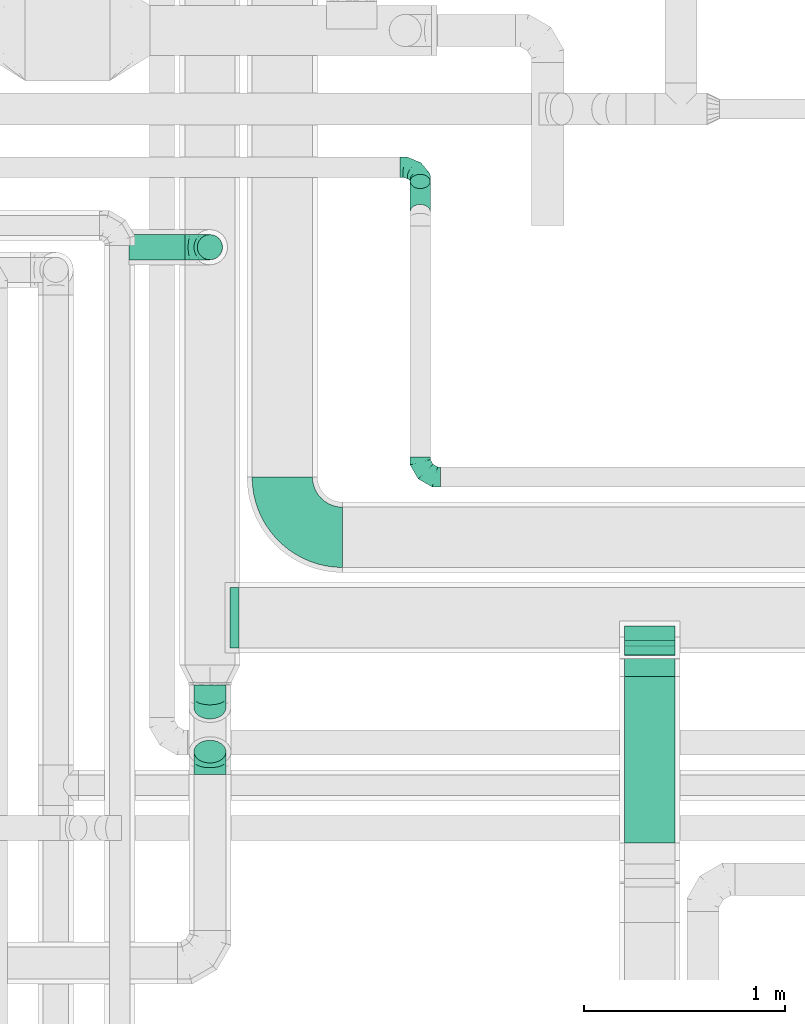
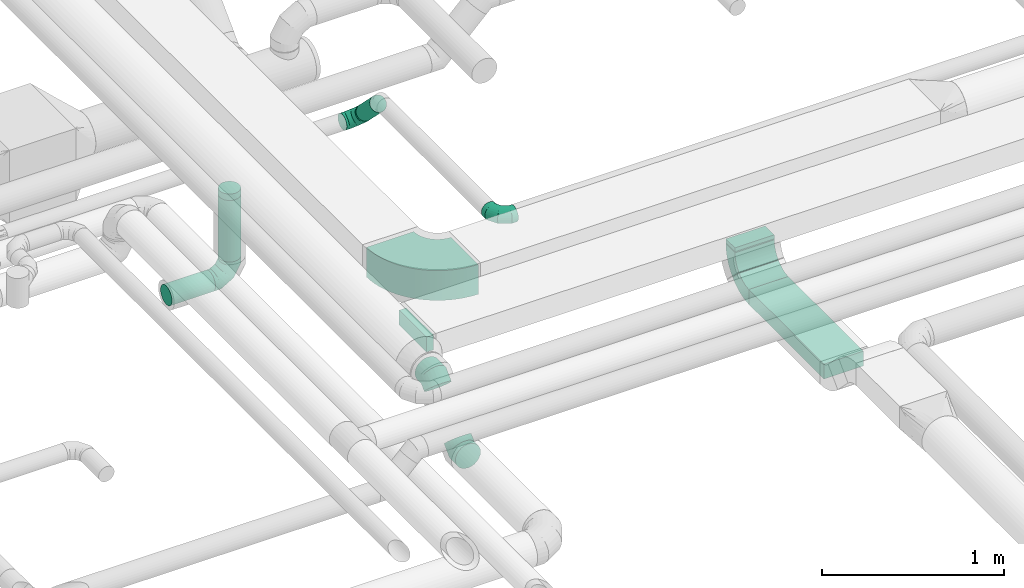
# One storey, part 68 of 92: 11 flow fittings, 6 flow segments.
"""IFC2X3 building model written with IfcOpenShell, lengths in millimetres."""

from ifc_helpers import new_model, entity, si_unit, converted_unit, derived_unit, direction, frame, frame_2d, origin, origin_2d_with_axis, place, context, subcontext, project, spatial, polyline, circle_curve, parameter, trimmed, segment, composite_curve, rectangle, circle, outline, extrude, faceted_brep, source, transform, mapped, material, type_object, type_shapes, element, save


model = new_model("IFC2X3")

# Units and contexts
model_context = context("Model", 3, precision=0.01, world=origin(), true_north=direction((6.12303176911189e-17, 1.0)))
body_context = subcontext(model_context, "Body", "Model", "MODEL_VIEW")
ifc_project = project(units=[si_unit("LENGTHUNIT", "METRE", prefix="MILLI"), si_unit("AREAUNIT", "SQUARE_METRE"), si_unit("VOLUMEUNIT", "CUBIC_METRE"), converted_unit("PLANEANGLEUNIT", "DEGREE", entity("IfcRatioMeasure", 0.0174532925199433), si_unit("PLANEANGLEUNIT", "RADIAN"), dimensions=[0, 0, 0, 0, 0, 0, 0]), si_unit("MASSUNIT", "GRAM", prefix="KILO"), derived_unit("MASSDENSITYUNIT", [(si_unit("MASSUNIT", "GRAM", prefix="KILO"), 1), (si_unit("LENGTHUNIT", "METRE"), -3)]), derived_unit("MOMENTOFINERTIAUNIT", [(si_unit("LENGTHUNIT", "METRE"), 4)]), si_unit("TIMEUNIT", "SECOND"), si_unit("FREQUENCYUNIT", "HERTZ"), si_unit("THERMODYNAMICTEMPERATUREUNIT", "DEGREE_CELSIUS"), derived_unit("THERMALTRANSMITTANCEUNIT", [(si_unit("MASSUNIT", "GRAM", prefix="KILO"), 1), (si_unit("THERMODYNAMICTEMPERATUREUNIT", "KELVIN"), -1), (si_unit("TIMEUNIT", "SECOND"), -3)]), derived_unit("VOLUMETRICFLOWRATEUNIT", [(si_unit("LENGTHUNIT", "METRE"), 3), (si_unit("TIMEUNIT", "SECOND"), -1)]), derived_unit("MASSFLOWRATEUNIT", [(si_unit("MASSUNIT", "GRAM", prefix="KILO"), 1), (si_unit("TIMEUNIT", "SECOND"), -1)]), derived_unit("ROTATIONALFREQUENCYUNIT", [(si_unit("TIMEUNIT", "SECOND"), -1)]), si_unit("ELECTRICCURRENTUNIT", "AMPERE"), si_unit("ELECTRICVOLTAGEUNIT", "VOLT"), si_unit("POWERUNIT", "WATT"), si_unit("FORCEUNIT", "NEWTON", prefix="KILO"), si_unit("ILLUMINANCEUNIT", "LUX"), si_unit("LUMINOUSFLUXUNIT", "LUMEN"), si_unit("LUMINOUSINTENSITYUNIT", "CANDELA"), derived_unit("USERDEFINED", [(si_unit("MASSUNIT", "GRAM", prefix="KILO"), -1), (si_unit("LENGTHUNIT", "METRE"), -2), (si_unit("TIMEUNIT", "SECOND"), 3), (si_unit("LUMINOUSFLUXUNIT", "LUMEN"), 1)]), derived_unit("LINEARVELOCITYUNIT", [(si_unit("LENGTHUNIT", "METRE"), 1), (si_unit("TIMEUNIT", "SECOND"), -1)]), si_unit("PRESSUREUNIT", "PASCAL"), derived_unit("USERDEFINED", [(si_unit("LENGTHUNIT", "METRE"), -2), (si_unit("MASSUNIT", "GRAM", prefix="KILO"), 1), (si_unit("TIMEUNIT", "SECOND"), -2)]), derived_unit("LINEARFORCEUNIT", [(si_unit("MASSUNIT", "GRAM", prefix="KILO"), 1), (si_unit("LENGTHUNIT", "METRE"), 1), (si_unit("TIMEUNIT", "SECOND"), -2), (si_unit("LENGTHUNIT", "METRE"), -1)]), derived_unit("PLANARFORCEUNIT", [(si_unit("MASSUNIT", "GRAM", prefix="KILO"), 1), (si_unit("LENGTHUNIT", "METRE"), 1), (si_unit("TIMEUNIT", "SECOND"), -2), (si_unit("LENGTHUNIT", "METRE"), -2)])], contexts=[model_context])

# Site, building, storey
site_placement = place(None, origin())
site = spatial("IfcSite", under=ifc_project, at=site_placement, CompositionType="ELEMENT")
building_placement = place(site_placement, origin())
building = spatial("IfcBuilding", under=site, at=building_placement, CompositionType="ELEMENT")
storey_placement = place(building_placement, frame((0.0, 0.0, 4200.0)))
storey = spatial("IfcBuildingStorey", under=building, at=storey_placement, CompositionType="ELEMENT", Elevation=4200.0)

# Flow segments
duct_segment_type_1 = type_object("IfcDuctSegmentType", PredefinedType="NOTDEFINED")
flow_segment_1_placement = place(storey_placement, frame((63146.35, 8456.55, 2970.0)))
element("IfcFlowSegment", 1, at=flow_segment_1_placement, inside=storey, type_object=duct_segment_type_1, context=body_context, shape_type="SweptSolid", body=[
    extrude(rectangle(XDim=825.783728094219, YDim=250.000000000004, at=origin_2d_with_axis()), frame((125.0, 412.89, 0.0), z_axis=(0.0, 0.0, 1.0), x_axis=(0.0, 1.0, 0.0)), (0.0, 0.0, 1.0), 99.9999999999989),
])
flow_segment_2_placement = place(storey_placement, frame((63146.35, 9435.17, 3222.84)))
element("IfcFlowSegment", 2, at=flow_segment_2_placement, inside=storey, type_object=duct_segment_type_1, context=body_context, shape_type="SweptSolid", body=[
    extrude(rectangle(XDim=249.999999999995, YDim=100.0, at=origin_2d_with_axis()), frame((125.0, 50.0, 0.0)), (0.0, 0.0, 1.0), 7.15728752542948),
])
flow_segment_3_placement = place(storey_placement, frame((63146.35, 9388.4, 3043.22)))
element("IfcFlowSegment", 3, at=flow_segment_3_placement, inside=storey, type_object=duct_segment_type_1, context=body_context, shape_type="SweptSolid", body=[
    extrude(rectangle(XDim=99.9999999999997, YDim=4.02020253560479, at=frame_2d((0.0, 0.0), x_axis=(0.0, 1.0))), frame((0.0, 36.78, 36.78), z_axis=(1.0, 0.0, 0.0), x_axis=(0.0, 0.707106781190723, 0.707106781182372)), (0.0, 0.0, 1.0), 249.999999999995),
])
duct_segment_type_2 = type_object("IfcDuctSegmentType", PredefinedType="NOTDEFINED")
flow_segment_4_placement = place(storey_placement, frame((60683.72, 11352.66, 2535.9)))
element("IfcFlowSegment", 4, at=flow_segment_4_placement, inside=storey, type_object=duct_segment_type_2, context=body_context, shape_type="SweptSolid", body=[
    extrude(circle(Radius=62.5, at=origin_2d_with_axis()), frame((0.0, 64.1, 64.1), z_axis=(1.0, 0.0, 0.0), x_axis=(0.0, -1.0, 0.0)), (0.0, 0.0, 1.0), 276.27551312413),
])
flow_segment_5_placement = place(storey_placement, frame((61020.9, 11352.66, 2725.0)))
element("IfcFlowSegment", 5, at=flow_segment_5_placement, inside=storey, type_object=duct_segment_type_2, context=body_context, shape_type="SweptSolid", body=[
    extrude(circle(Radius=62.5, at=origin_2d_with_axis()), frame((64.1, 64.1, 0.0), z_axis=(0.0, 0.0, 1.0), x_axis=(0.0, -1.0, 0.0)), (0.0, 0.0, 1.0), 412.500000000016),
])
duct_segment_type_3 = type_object("IfcDuctSegmentType", PredefinedType="NOTDEFINED")
flow_segment_6_placement = place(storey_placement, frame((62078.4, 11556.54, 3083.76)))
element("IfcFlowSegment", 6, at=flow_segment_6_placement, inside=storey, type_object=duct_segment_type_3, context=body_context, shape_type="SweptSolid", body=[
    extrude(circle(Radius=50.0, at=origin_2d_with_axis()), frame((51.6, 186.95, 36.95), z_axis=(0.0, -0.707106781186563, 0.707106781186532), x_axis=(-1.0, 0.0, 0.0)), (0.0, 0.0, 1.0), 212.132034355984),
])

# Flow fittings
ifc_material = material()
duct_fitting_type_1 = type_object("IfcDuctFittingType", PredefinedType="NOTDEFINED", material=ifc_material)
shared_shape_1 = source(origin(), body_context, "Body", "SweptSolid", [
    extrude(rectangle(XDim=300.0, YDim=44.6568108823504, at=origin_2d_with_axis()), frame((-2.33, 0.0, -50.0), z_axis=(0.0, 0.0, 1.0), x_axis=(0.0, -1.0, 0.0)), (0.0, 0.0, 1.0), 100.0),
])
type_shapes(duct_fitting_type_1, [shared_shape_1])
flow_fitting_1_placement = place(storey_placement, frame((61208.77, 9575.17, 3300.0), z_axis=(0.0, 0.0, -1.0), x_axis=(1.0, 0.0, 0.0)))
element("IfcFlowFitting", 7, at=flow_fitting_1_placement, inside=storey, type_object=duct_fitting_type_1, material=ifc_material, context=body_context, shape_type="MappedRepresentation", body=[
    mapped(shared_shape_1, transform((0.0, 0.0, 0.0), scale=1.0)),
])
duct_fitting_type_2 = type_object("IfcDuctFittingType", PredefinedType="NOTDEFINED", material=ifc_material)
shared_shape_2 = source(origin(), body_context, "Body", "SweptSolid", [
    extrude(rectangle(XDim=250.0, YDim=26.096, at=origin_2d_with_axis()), frame((6.95, 0.0, -50.0), z_axis=(0.0, 0.0, 1.0), x_axis=(0.0, -1.0, 0.0)), (0.0, 0.0, 1.0), 100.0),
])
type_shapes(duct_fitting_type_2, [shared_shape_2])
flow_fitting_2_placement = place(storey_placement, frame((63271.35, 9485.17, 3250.0), z_axis=(0.0, 1.0, 0.0), x_axis=(0.0, 0.0, -1.0)))
element("IfcFlowFitting", 8, at=flow_fitting_2_placement, inside=storey, type_object=duct_fitting_type_2, material=ifc_material, context=body_context, shape_type="MappedRepresentation", body=[
    mapped(shared_shape_2, transform((0.0, 0.0, 0.0), scale=1.0)),
])
duct_fitting_type_3 = type_object("IfcDuctFittingType", PredefinedType="NOTDEFINED", material=ifc_material)
shared_shape_3 = source(origin(), body_context, "Body", "Brep", [
    faceted_brep([(-100.0, 0.0, -50.0), (-100.0, -12.94, -48.3), (-100.0, -25.0, -43.3), (-100.0, -35.36, -35.36), (-100.0, -43.3, -25.0), (-100.0, -48.3, -12.94), (-100.0, -50.0, 0.0), (-100.0, -48.3, 12.94), (-100.0, -43.3, 25.0), (-100.0, -35.36, 35.36), (-100.0, -25.0, 43.3), (-100.0, -12.94, 48.3), (-100.0, 0.0, 50.0), (-100.0, 12.94, 48.3), (-100.0, 25.0, 43.3), (-100.0, 35.36, 35.36), (-100.0, 43.3, 25.0), (-100.0, 48.3, 12.94), (-100.0, 50.0, 0.0), (-100.0, 48.3, -12.94), (-100.0, 43.3, -25.0), (-100.0, 35.36, -35.36), (-100.0, 25.0, -43.3), (-100.0, 12.94, -48.3), (-76.67, 12.94, 48.3), (-79.9, 25.0, 43.3), (-73.21, 0.0, 50.0), (-82.68, 35.36, 35.36), (-86.15, 48.3, 12.94), (-86.6, 50.0, 0.0), (-84.81, 43.3, 25.0), (-84.81, 43.3, -25.0), (-82.68, 35.36, -35.36), (-86.15, 48.3, -12.94), (-76.67, 12.94, -48.3), (-73.21, 0.0, -50.0), (-79.9, 25.0, -43.3), (-69.74, -12.94, -48.3), (-66.51, -25.0, -43.3), (-63.73, -35.36, -35.36), (-61.6, -43.3, -25.0), (-60.26, -48.3, -12.94), (-59.81, -50.0, 0.0), (-60.26, -48.3, 12.94), (-61.6, -43.3, 25.0), (-63.73, -35.36, 35.36), (-66.51, -25.0, 43.3), (-69.74, -12.94, 48.3), (-36.27, 36.27, 48.3), (-45.1, 45.1, 43.3), (-26.79, 26.79, 50.0), (-52.68, 52.68, 35.36), (-58.49, 58.49, 25.0), (-62.15, 62.15, 12.94), (-63.4, 63.4, 0.0), (-62.15, 62.15, -12.94), (-58.49, 58.49, -25.0), (-52.68, 52.68, -35.36), (-36.27, 36.27, -48.3), (-26.79, 26.79, -50.0), (-45.1, 45.1, -43.3), (-17.32, 17.32, -48.3), (-8.49, 8.49, -43.3), (-0.91, 0.91, -35.36), (4.9, -4.9, -25.0), (8.56, -8.56, -12.94), (9.81, -9.81, 0.0), (8.56, -8.56, 12.94), (4.9, -4.9, 25.0), (-0.91, 0.91, 35.36), (-8.49, 8.49, 43.3), (-17.32, 17.32, 48.3), (-12.94, 76.67, 48.3), (-25.0, 79.9, 43.3), (0.0, 73.21, 50.0), (-35.36, 82.68, 35.36), (-43.3, 84.81, 25.0), (-48.3, 86.15, 12.94), (-50.0, 86.6, 0.0), (-48.3, 86.15, -12.94), (-43.3, 84.81, -25.0), (-35.36, 82.68, -35.36), (-12.94, 76.67, -48.3), (0.0, 73.21, -50.0), (-25.0, 79.9, -43.3), (12.94, 69.74, -48.3), (25.0, 66.51, -43.3), (35.36, 63.73, -35.36), (43.3, 61.6, -25.0), (48.3, 60.26, -12.94), (50.0, 59.81, 0.0), (48.3, 60.26, 12.94), (43.3, 61.6, 25.0), (35.36, 63.73, 35.36), (25.0, 66.51, 43.3), (12.94, 69.74, 48.3), (-12.94, 100.0, -48.3), (-25.0, 100.0, -43.3), (-35.36, 100.0, -35.36), (-43.3, 100.0, -25.0), (-48.3, 100.0, -12.94), (-50.0, 100.0, 0.0), (-48.3, 100.0, 12.94), (-43.3, 100.0, 25.0), (-35.36, 100.0, 35.36), (-25.0, 100.0, 43.3), (-12.94, 100.0, 48.3), (0.0, 100.0, 50.0), (12.94, 100.0, 48.3), (25.0, 100.0, 43.3), (35.36, 100.0, 35.36), (43.3, 100.0, 25.0), (48.3, 100.0, 12.94), (50.0, 100.0, 0.0), (48.3, 100.0, -12.94), (43.3, 100.0, -25.0), (35.36, 100.0, -35.36), (25.0, 100.0, -43.3), (12.94, 100.0, -48.3), (0.0, 100.0, -50.0)], [[[0, 1, 2, 3, 4, 5, 6, 7, 8, 9, 10, 11, 12, 13, 14, 15, 16, 17, 18, 19, 20, 21, 22, 23]], [[24, 25, 14, 13]], [[26, 24, 13, 12]], [[14, 25, 27, 15]], [[28, 29, 18, 17]], [[30, 28, 17, 16]], [[15, 27, 30, 16]], [[20, 31, 32, 21]], [[33, 31, 20, 19]], [[18, 29, 33, 19]], [[34, 35, 0, 23]], [[36, 34, 23, 22]], [[32, 36, 22, 21]], [[2, 1, 37, 38]], [[3, 2, 38, 39]], [[0, 35, 37, 1]], [[5, 4, 40, 41]], [[6, 5, 41, 42]], [[3, 39, 40, 4]], [[6, 42, 43, 7]], [[7, 43, 44, 8]], [[8, 44, 45, 9]], [[10, 46, 47, 11]], [[11, 47, 26, 12]], [[10, 9, 45, 46]], [[48, 49, 25, 24]], [[50, 48, 24, 26]], [[27, 25, 49, 51]], [[52, 53, 28, 30]], [[51, 52, 30, 27]], [[29, 28, 53, 54]], [[55, 56, 31, 33]], [[54, 55, 33, 29]], [[57, 32, 31, 56]], [[58, 59, 35, 34]], [[60, 58, 34, 36]], [[57, 60, 36, 32]], [[37, 35, 59, 61]], [[38, 37, 61, 62]], [[39, 38, 62, 63]], [[41, 40, 64, 65]], [[42, 41, 65, 66]], [[63, 64, 40, 39]], [[43, 42, 66, 67]], [[44, 43, 67, 68]], [[68, 69, 45, 44]], [[46, 45, 69, 70]], [[47, 46, 70, 71]], [[26, 47, 71, 50]], [[72, 73, 49, 48]], [[74, 72, 48, 50]], [[51, 49, 73, 75]], [[76, 77, 53, 52]], [[75, 76, 52, 51]], [[54, 53, 77, 78]], [[79, 80, 56, 55]], [[78, 79, 55, 54]], [[81, 57, 56, 80]], [[82, 83, 59, 58]], [[84, 82, 58, 60]], [[81, 84, 60, 57]], [[61, 59, 83, 85]], [[62, 61, 85, 86]], [[63, 62, 86, 87]], [[65, 64, 88, 89]], [[66, 65, 89, 90]], [[87, 88, 64, 63]], [[67, 66, 90, 91]], [[68, 67, 91, 92]], [[92, 93, 69, 68]], [[70, 69, 93, 94]], [[71, 70, 94, 95]], [[50, 71, 95, 74]], [[96, 97, 98, 99, 100, 101, 102, 103, 104, 105, 106, 107, 108, 109, 110, 111, 112, 113, 114, 115, 116, 117, 118, 119]], [[72, 74, 107, 106]], [[73, 72, 106, 105]], [[75, 73, 105, 104]], [[77, 76, 103, 102]], [[78, 77, 102, 101]], [[75, 104, 103, 76]], [[78, 101, 100, 79]], [[79, 100, 99, 80]], [[80, 99, 98, 81]], [[96, 119, 83, 82]], [[97, 96, 82, 84]], [[84, 81, 98, 97]], [[83, 119, 118, 85]], [[85, 118, 117, 86]], [[86, 117, 116, 87]], [[88, 115, 114, 89]], [[89, 114, 113, 90]], [[87, 116, 115, 88]], [[91, 90, 113, 112]], [[92, 91, 112, 111]], [[93, 92, 111, 110]], [[95, 94, 109, 108]], [[74, 95, 108, 107]], [[110, 109, 94, 93]]]),
])
type_shapes(duct_fitting_type_3, [shared_shape_3])
for number, where, z_axis, x_axis in (
    (9, (62130.0, 11814.2, 3050.0), (0.0, -0.707106781186548, -0.707106781186548), (1.0, 0.0, 0.0)),
    (10, (62130.0, 10274.95, 3300.0), (3.51023922022513e-05, 0.0, 1.0), (0.0, -1.0, 0.0)),
):
    element("IfcFlowFitting", number, at=place(storey_placement, frame(where, z_axis=z_axis, x_axis=x_axis)), inside=storey, type_object=duct_fitting_type_3, material=ifc_material, context=body_context, shape_type="MappedRepresentation", body=[
        mapped(shared_shape_3, transform((0.0, 0.0, 0.0), scale=1.0)),
    ])
duct_fitting_type_4 = type_object("IfcDuctFittingType", PredefinedType="NOTDEFINED", material=ifc_material)
shared_shape_4 = source(origin(), body_context, "Body", "Brep", [
    faceted_brep([(-125.0, 0.0, -62.5), (-125.0, -16.18, -60.37), (-125.0, -31.25, -54.13), (-125.0, -44.19, -44.19), (-125.0, -54.13, -31.25), (-125.0, -60.37, -16.18), (-125.0, -62.5, 0.0), (-125.0, -60.37, 16.18), (-125.0, -54.13, 31.25), (-125.0, -44.19, 44.19), (-125.0, -31.25, 54.13), (-125.0, -16.18, 60.37), (-125.0, 0.0, 62.5), (-125.0, 16.18, 60.37), (-125.0, 31.25, 54.13), (-125.0, 44.19, 44.19), (-125.0, 54.13, 31.25), (-125.0, 60.37, 16.18), (-125.0, 62.5, 0.0), (-125.0, 60.37, -16.18), (-125.0, 54.13, -31.25), (-125.0, 44.19, -44.19), (-125.0, 31.25, -54.13), (-125.0, 16.18, -60.37), (-95.84, 16.18, 60.37), (-99.88, 31.25, 54.13), (-91.51, 0.0, 62.5), (-103.35, 44.19, 44.19), (-107.68, 60.37, 16.18), (-108.25, 62.5, 0.0), (-106.01, 54.13, 31.25), (-106.01, 54.13, -31.25), (-103.35, 44.19, -44.19), (-107.68, 60.37, -16.18), (-95.84, 16.18, -60.37), (-91.51, 0.0, -62.5), (-99.88, 31.25, -54.13), (-87.17, -16.18, -60.37), (-83.13, -31.25, -54.13), (-79.66, -44.19, -44.19), (-77.0, -54.13, -31.25), (-75.33, -60.37, -16.18), (-74.76, -62.5, 0.0), (-75.33, -60.37, 16.18), (-77.0, -54.13, 31.25), (-79.66, -44.19, 44.19), (-83.13, -31.25, 54.13), (-87.17, -16.18, 60.37), (-45.34, 45.34, 60.37), (-56.37, 56.37, 54.13), (-33.49, 33.49, 62.5), (-65.85, 65.85, 44.19), (-73.12, 73.12, 31.25), (-77.69, 77.69, 16.18), (-79.25, 79.25, 0.0), (-77.69, 77.69, -16.18), (-73.12, 73.12, -31.25), (-65.85, 65.85, -44.19), (-45.34, 45.34, -60.37), (-33.49, 33.49, -62.5), (-56.37, 56.37, -54.13), (-21.65, 21.65, -60.37), (-10.62, 10.62, -54.13), (-1.14, 1.14, -44.19), (6.13, -6.13, -31.25), (10.7, -10.7, -16.18), (12.26, -12.26, 0.0), (10.7, -10.7, 16.18), (6.13, -6.13, 31.25), (-1.14, 1.14, 44.19), (-10.62, 10.62, 54.13), (-21.65, 21.65, 60.37), (-16.18, 95.84, 60.37), (-31.25, 99.88, 54.13), (0.0, 91.51, 62.5), (-44.19, 103.35, 44.19), (-54.13, 106.01, 31.25), (-60.37, 107.68, 16.18), (-62.5, 108.25, 0.0), (-60.37, 107.68, -16.18), (-54.13, 106.01, -31.25), (-44.19, 103.35, -44.19), (-16.18, 95.84, -60.37), (0.0, 91.51, -62.5), (-31.25, 99.88, -54.13), (16.18, 87.17, -60.37), (31.25, 83.13, -54.13), (44.19, 79.66, -44.19), (54.13, 77.0, -31.25), (60.37, 75.33, -16.18), (62.5, 74.76, 0.0), (60.37, 75.33, 16.18), (54.13, 77.0, 31.25), (44.19, 79.66, 44.19), (31.25, 83.13, 54.13), (16.18, 87.17, 60.37), (-16.18, 125.0, -60.37), (-31.25, 125.0, -54.13), (-44.19, 125.0, -44.19), (-54.13, 125.0, -31.25), (-60.37, 125.0, -16.18), (-62.5, 125.0, 0.0), (-60.37, 125.0, 16.18), (-54.13, 125.0, 31.25), (-44.19, 125.0, 44.19), (-31.25, 125.0, 54.13), (-16.18, 125.0, 60.37), (0.0, 125.0, 62.5), (16.18, 125.0, 60.37), (31.25, 125.0, 54.13), (44.19, 125.0, 44.19), (54.13, 125.0, 31.25), (60.37, 125.0, 16.18), (62.5, 125.0, 0.0), (60.37, 125.0, -16.18), (54.13, 125.0, -31.25), (44.19, 125.0, -44.19), (31.25, 125.0, -54.13), (16.18, 125.0, -60.37), (0.0, 125.0, -62.5)], [[[0, 1, 2, 3, 4, 5, 6, 7, 8, 9, 10, 11, 12, 13, 14, 15, 16, 17, 18, 19, 20, 21, 22, 23]], [[24, 25, 14, 13]], [[26, 24, 13, 12]], [[14, 25, 27, 15]], [[28, 29, 18, 17]], [[30, 28, 17, 16]], [[15, 27, 30, 16]], [[20, 31, 32, 21]], [[33, 31, 20, 19]], [[18, 29, 33, 19]], [[34, 35, 0, 23]], [[36, 34, 23, 22]], [[21, 32, 36, 22]], [[1, 0, 35, 37]], [[2, 1, 37, 38]], [[38, 39, 3, 2]], [[5, 4, 40, 41]], [[6, 5, 41, 42]], [[39, 40, 4, 3]], [[6, 42, 43, 7]], [[7, 43, 44, 8]], [[45, 9, 8, 44]], [[9, 45, 46, 10]], [[10, 46, 47, 11]], [[26, 12, 11, 47]], [[48, 49, 25, 24]], [[50, 48, 24, 26]], [[27, 25, 49, 51]], [[52, 53, 28, 30]], [[51, 52, 30, 27]], [[29, 28, 53, 54]], [[55, 56, 31, 33]], [[54, 55, 33, 29]], [[57, 32, 31, 56]], [[58, 59, 35, 34]], [[60, 58, 34, 36]], [[57, 60, 36, 32]], [[37, 35, 59, 61]], [[38, 37, 61, 62]], [[39, 38, 62, 63]], [[41, 40, 64, 65]], [[42, 41, 65, 66]], [[63, 64, 40, 39]], [[43, 42, 66, 67]], [[44, 43, 67, 68]], [[68, 69, 45, 44]], [[46, 45, 69, 70]], [[47, 46, 70, 71]], [[26, 47, 71, 50]], [[72, 73, 49, 48]], [[74, 72, 48, 50]], [[51, 49, 73, 75]], [[76, 77, 53, 52]], [[75, 76, 52, 51]], [[54, 53, 77, 78]], [[79, 80, 56, 55]], [[78, 79, 55, 54]], [[81, 57, 56, 80]], [[82, 83, 59, 58]], [[84, 82, 58, 60]], [[81, 84, 60, 57]], [[61, 59, 83, 85]], [[62, 61, 85, 86]], [[63, 62, 86, 87]], [[65, 64, 88, 89]], [[66, 65, 89, 90]], [[87, 88, 64, 63]], [[67, 66, 90, 91]], [[68, 67, 91, 92]], [[92, 93, 69, 68]], [[70, 69, 93, 94]], [[71, 70, 94, 95]], [[50, 71, 95, 74]], [[96, 97, 98, 99, 100, 101, 102, 103, 104, 105, 106, 107, 108, 109, 110, 111, 112, 113, 114, 115, 116, 117, 118, 119]], [[72, 74, 107, 106]], [[73, 72, 106, 105]], [[75, 73, 105, 104]], [[77, 76, 103, 102]], [[78, 77, 102, 101]], [[75, 104, 103, 76]], [[78, 101, 100, 79]], [[79, 100, 99, 80]], [[80, 99, 98, 81]], [[96, 119, 83, 82]], [[97, 96, 82, 84]], [[84, 81, 98, 97]], [[83, 119, 118, 85]], [[85, 118, 117, 86]], [[116, 87, 86, 117]], [[88, 115, 114, 89]], [[89, 114, 113, 90]], [[115, 88, 87, 116]], [[91, 90, 113, 112]], [[92, 91, 112, 111]], [[111, 110, 93, 92]], [[95, 94, 109, 108]], [[74, 95, 108, 107]], [[110, 109, 94, 93]]]),
])
type_shapes(duct_fitting_type_4, [shared_shape_4])
flow_fitting_3_placement = place(storey_placement, frame((61085.0, 11416.75, 2600.0), z_axis=(0.0, -1.0, 0.0), x_axis=(1.0, 0.0, 0.0)))
element("IfcFlowFitting", 11, at=flow_fitting_3_placement, inside=storey, type_object=duct_fitting_type_4, material=ifc_material, context=body_context, shape_type="MappedRepresentation", body=[
    mapped(shared_shape_4, transform((0.0, 0.0, 0.0), scale=1.0)),
])
duct_fitting_type_5 = type_object("IfcDuctFittingType", PredefinedType="NOTDEFINED", material=ifc_material)
shared_shape_5 = source(origin(), body_context, "Body", "Brep", [
    faceted_brep([(-66.27, 0.0, -80.0), (-66.27, -20.71, -77.27), (-66.27, -40.0, -69.28), (-66.27, -56.57, -56.57), (-66.27, -69.28, -40.0), (-66.27, -77.27, -20.71), (-66.27, -80.0, 0.0), (-66.27, -77.27, 20.71), (-66.27, -69.28, 40.0), (-66.27, -56.57, 56.57), (-66.27, -40.0, 69.28), (-66.27, -20.71, 77.27), (-66.27, 0.0, 80.0), (-66.27, 20.71, 77.27), (-66.27, 40.0, 69.28), (-66.27, 56.57, 56.57), (-66.27, 69.28, 40.0), (-66.27, 77.27, 20.71), (-66.27, 80.0, 0.0), (-66.27, 77.27, -20.71), (-66.27, 69.28, -40.0), (-66.27, 56.57, -56.57), (-66.27, 40.0, -69.28), (-66.27, 20.71, -77.27), (-8.58, 20.71, 77.27), (-16.57, 40.0, 69.28), (0.0, 0.0, 80.0), (-23.43, 56.57, 56.57), (-28.7, 69.28, 40.0), (-32.01, 77.27, 20.71), (-33.14, 80.0, 0.0), (-32.01, 77.27, -20.71), (-28.7, 69.28, -40.0), (-23.43, 56.57, -56.57), (-8.58, 20.71, -77.27), (0.0, 0.0, -80.0), (-16.57, 40.0, -69.28), (8.58, -20.71, -77.27), (16.57, -40.0, -69.28), (23.43, -56.57, -56.57), (28.7, -69.28, -40.0), (32.01, -77.27, -20.71), (33.14, -80.0, 0.0), (32.01, -77.27, 20.71), (28.7, -69.28, 40.0), (23.43, -56.57, 56.57), (16.57, -40.0, 69.28), (8.58, -20.71, 77.27), (46.86, 46.86, 80.0), (32.22, 61.5, 77.27), (18.58, 75.15, 69.28), (6.86, 86.86, 56.57), (-2.13, 95.85, 40.0), (-7.78, 101.5, 20.71), (-9.71, 103.43, 0.0), (-7.78, 101.5, -20.71), (-2.13, 95.85, -40.0), (6.86, 86.86, -56.57), (18.58, 75.15, -69.28), (32.22, 61.5, -77.27), (46.86, 46.86, -80.0), (61.5, 32.22, -77.27), (75.15, 18.58, -69.28), (86.86, 6.86, -56.57), (95.85, -2.13, -40.0), (101.5, -7.78, -20.71), (103.43, -9.71, 0.0), (101.5, -7.78, 20.71), (95.85, -2.13, 40.0), (86.86, 6.86, 56.57), (75.15, 18.58, 69.28), (61.5, 32.22, 77.27)], [[[0, 1, 2, 3, 4, 5, 6, 7, 8, 9, 10, 11, 12, 13, 14, 15, 16, 17, 18, 19, 20, 21, 22, 23]], [[24, 25, 14, 13]], [[26, 24, 13, 12]], [[14, 25, 27, 15]], [[28, 29, 17, 16]], [[28, 16, 15, 27]], [[30, 18, 17, 29]], [[31, 32, 20, 19]], [[30, 31, 19, 18]], [[32, 33, 21, 20]], [[34, 35, 0, 23]], [[36, 34, 23, 22]], [[33, 36, 22, 21]], [[1, 0, 35, 37]], [[2, 1, 37, 38]], [[38, 39, 3, 2]], [[5, 4, 40, 41]], [[6, 5, 41, 42]], [[39, 40, 4, 3]], [[6, 42, 43, 7]], [[7, 43, 44, 8]], [[8, 44, 45, 9]], [[9, 45, 46, 10]], [[10, 46, 47, 11]], [[26, 12, 11, 47]], [[24, 26, 48, 49]], [[25, 24, 49, 50]], [[27, 25, 50, 51]], [[29, 28, 52, 53]], [[30, 29, 53, 54]], [[51, 52, 28, 27]], [[30, 54, 55, 31]], [[31, 55, 56, 32]], [[57, 33, 32, 56]], [[36, 58, 59, 34]], [[34, 59, 60, 35]], [[58, 36, 33, 57]], [[35, 60, 61, 37]], [[37, 61, 62, 38]], [[63, 39, 38, 62]], [[40, 64, 65, 41]], [[41, 65, 66, 42]], [[64, 40, 39, 63]], [[43, 42, 66, 67]], [[44, 43, 67, 68]], [[68, 69, 45, 44]], [[47, 46, 70, 71]], [[26, 47, 71, 48]], [[69, 70, 46, 45]], [[59, 58, 57, 56, 55, 54, 53, 52, 51, 50, 49, 48, 71, 70, 69, 68, 67, 66, 65, 64, 63, 62, 61, 60]]]),
])
type_shapes(duct_fitting_type_5, [shared_shape_5])
for number, where, z_axis, x_axis in (
    (12, (61085.0, 9175.42, 3282.5), (1.0, 0.0, 0.0), (0.0, -1.0, 0.0)),
    (13, (61085.0, 8862.92, 2970.0), (-1.0, 0.0, 0.0), (0.0, -0.707106781186507, -0.707106781186588)),
):
    element("IfcFlowFitting", number, at=place(storey_placement, frame(where, z_axis=z_axis, x_axis=x_axis)), inside=storey, type_object=duct_fitting_type_5, material=ifc_material, context=body_context, shape_type="MappedRepresentation", body=[
        mapped(shared_shape_5, transform((0.0, 0.0, 0.0), scale=1.0)),
    ])
duct_fitting_type_6 = type_object("IfcDuctFittingType", PredefinedType="NOTDEFINED", material=ifc_material)
shared_shape_6 = source(origin(), body_context, "Body", "Brep", [
    faceted_brep([(20.0, 16.18, -60.37), (20.0, 31.25, -54.13), (20.0, 44.19, -44.19), (20.0, 54.13, -31.25), (20.0, 60.37, -16.18), (20.0, 62.5, 0.0), (20.0, 60.37, 16.18), (20.0, 54.13, 31.25), (20.0, 44.19, 44.19), (20.0, 31.25, 54.13), (20.0, 16.18, 60.37), (20.0, 0.0, 62.5), (20.0, -16.18, 60.37), (20.0, -31.25, 54.13), (20.0, -44.19, 44.19), (20.0, -54.13, 31.25), (20.0, -60.37, 16.18), (20.0, -62.5, 0.0), (20.0, -60.37, -16.18), (20.0, -54.13, -31.25), (20.0, -44.19, -44.19), (20.0, -31.25, -54.13), (20.0, -16.18, -60.37), (20.0, 0.0, -62.5), (0.0, 0.0, 62.5), (0.0, 16.18, 60.37), (-22.84, 16.18, 60.37), (-22.84, 0.0, 62.5), (0.0, 31.25, 54.13), (-22.84, 31.25, 54.13), (0.0, 44.19, 44.19), (-22.84, 44.19, 44.19), (0.0, 54.13, 31.25), (0.0, 60.37, 16.18), (-22.84, 60.37, 16.18), (-22.84, 54.13, 31.25), (0.0, 62.5, 0.0), (-22.84, 62.5, 0.0), (0.0, 60.37, -16.18), (-22.84, 60.37, -16.18), (0.0, 54.13, -31.25), (-22.84, 54.13, -31.25), (0.0, 44.19, -44.19), (-22.84, 44.19, -44.19), (0.0, 31.25, -54.13), (0.0, 16.18, -60.37), (-22.84, 16.18, -60.37), (-22.84, 31.25, -54.13), (0.0, 0.0, -62.5), (-22.84, 0.0, -62.5), (0.0, -16.18, -60.37), (-22.84, -16.18, -60.37), (0.0, -31.25, -54.13), (-22.84, -31.25, -54.13), (0.0, -44.19, -44.19), (-22.84, -44.19, -44.19), (0.0, -54.13, -31.25), (0.0, -60.37, -16.18), (-22.84, -60.37, -16.18), (-22.84, -54.13, -31.25), (0.0, -62.5, 0.0), (-22.84, -62.5, 0.0), (0.0, -60.37, 16.18), (-22.84, -60.37, 16.18), (0.0, -54.13, 31.25), (-22.84, -54.13, 31.25), (0.0, -44.19, 44.19), (-22.84, -44.19, 44.19), (0.0, -31.25, 54.13), (0.0, -16.18, 60.37), (-22.84, -16.18, 60.37), (-22.84, -31.25, 54.13)], [[[0, 1, 2, 3, 4, 5, 6, 7, 8, 9, 10, 11, 12, 13, 14, 15, 16, 17, 18, 19, 20, 21, 22, 23]], [[24, 11, 10, 25, 26, 27]], [[25, 10, 9, 28, 29, 26]], [[28, 9, 8, 30, 31, 29]], [[32, 7, 6, 33, 34, 35]], [[33, 6, 5, 36, 37, 34]], [[30, 8, 7, 32, 35, 31]], [[36, 5, 4, 38, 39, 37]], [[38, 4, 3, 40, 41, 39]], [[40, 3, 2, 42, 43, 41]], [[44, 1, 0, 45, 46, 47]], [[45, 0, 23, 48, 49, 46]], [[42, 2, 1, 44, 47, 43]], [[48, 23, 22, 50, 51, 49]], [[50, 22, 21, 52, 53, 51]], [[52, 21, 20, 54, 55, 53]], [[56, 19, 18, 57, 58, 59]], [[57, 18, 17, 60, 61, 58]], [[54, 20, 19, 56, 59, 55]], [[60, 17, 16, 62, 63, 61]], [[62, 16, 15, 64, 65, 63]], [[64, 15, 14, 66, 67, 65]], [[68, 13, 12, 69, 70, 71]], [[69, 12, 11, 24, 27, 70]], [[66, 14, 13, 68, 71, 67]], [[49, 51, 53, 55, 59, 58, 61, 63, 65, 67, 71, 70, 27, 26, 29, 31, 35, 34, 37, 39, 41, 43, 47, 46]]]),
])
type_shapes(duct_fitting_type_6, [shared_shape_6])
flow_fitting_4_placement = place(storey_placement, frame((61085.0, 11416.75, 3157.5), z_axis=(-1.0, 0.0, 0.0), x_axis=(0.0, 0.0, -1.0)))
element("IfcFlowFitting", 14, at=flow_fitting_4_placement, inside=storey, type_object=duct_fitting_type_6, material=ifc_material, context=body_context, shape_type="MappedRepresentation", body=[
    mapped(shared_shape_6, transform((0.0, 0.0, 0.0), scale=1.0)),
])
duct_fitting_type_7 = type_object("IfcDuctFittingType", PredefinedType="NOTDEFINED", material=ifc_material)
shared_shape_7 = source(origin(), body_context, "Body", "SweptSolid", [
    extrude(outline(composite_curve([segment(polyline([(-300.0, -150.0), (0.0, -150.0)]), True, "CONTINUOUS"), segment(trimmed(circle_curve(frame_2d((150.0, -150.0), x_axis=(0.0, 1.0)), 150.0), [parameter(0.0)], [parameter(90.0)], True, "PARAMETER"), False, "CONTINUOUS"), segment(polyline([(150.0, 0.0), (150.0, 300.0)]), True, "CONTINUOUS"), segment(trimmed(circle_curve(frame_2d((150.0, -150.0), x_axis=(0.0, 1.0)), 450.0), [parameter(0.0)], [parameter(90.0000000000001)], True, "PARAMETER"), True, "CONTINUOUS")], self_intersect=False)), frame((-150.0, 150.0, -100.0), z_axis=(0.0, 0.0, 1.0), x_axis=(-1.0, 0.0, 0.0)), (0.0, 0.0, 1.0), 200.0),
])
type_shapes(duct_fitting_type_7, [shared_shape_7])
flow_fitting_5_placement = place(storey_placement, frame((61444.33, 9974.93, 3300.0), z_axis=(0.0, 0.0, 1.0), x_axis=(0.0, -1.0, 0.0)))
element("IfcFlowFitting", 15, at=flow_fitting_5_placement, inside=storey, type_object=duct_fitting_type_7, material=ifc_material, context=body_context, shape_type="MappedRepresentation", body=[
    mapped(shared_shape_7, transform((0.0, 0.0, 0.0), scale=1.0)),
])
duct_fitting_type_8 = type_object("IfcDuctFittingType", PredefinedType="NOTDEFINED", material=ifc_material)
shared_shape_8 = source(origin(), body_context, "Body", "SweptSolid", [
    extrude(outline(composite_curve([segment(polyline([(-79.29, -70.71), (20.71, -70.71)]), True, "CONTINUOUS"), segment(trimmed(circle_curve(frame_2d((170.71, -70.71), x_axis=(-0.70710678118655, 0.707106781186546)), 150.0), [parameter(0.0)], [parameter(45.0)], True, "PARAMETER"), False, "CONTINUOUS"), segment(polyline([(64.64, 35.36), (-6.07, 106.07)]), True, "CONTINUOUS"), segment(trimmed(circle_curve(frame_2d((170.71, -70.71), x_axis=(-0.70710678118655, 0.707106781186546)), 250.0), [parameter(0.0)], [parameter(45.0)], True, "PARAMETER"), True, "CONTINUOUS")], self_intersect=False)), frame((-12.13, 29.29, -125.0), z_axis=(0.0, 0.0, 1.0), x_axis=(-0.707106781186547, 0.707106781186548, 0.0)), (0.0, 0.0, 1.0), 250.0),
])
type_shapes(duct_fitting_type_8, [shared_shape_8])
for number, where, z_axis, x_axis in (
    (16, (63271.35, 9365.17, 3020.0), (1.0, 0.0, 0.0), (0.0, 1.0, 0.0)),
    (17, (63271.35, 9485.17, 3140.0), (-1.0, 0.0, 0.0), (0.0, 0.0, -1.0)),
):
    element("IfcFlowFitting", number, at=place(storey_placement, frame(where, z_axis=z_axis, x_axis=x_axis)), inside=storey, type_object=duct_fitting_type_8, material=ifc_material, context=body_context, shape_type="MappedRepresentation", body=[
        mapped(shared_shape_8, transform((0.0, 0.0, 0.0), scale=1.0)),
    ])

save(model, "model.ifc")
